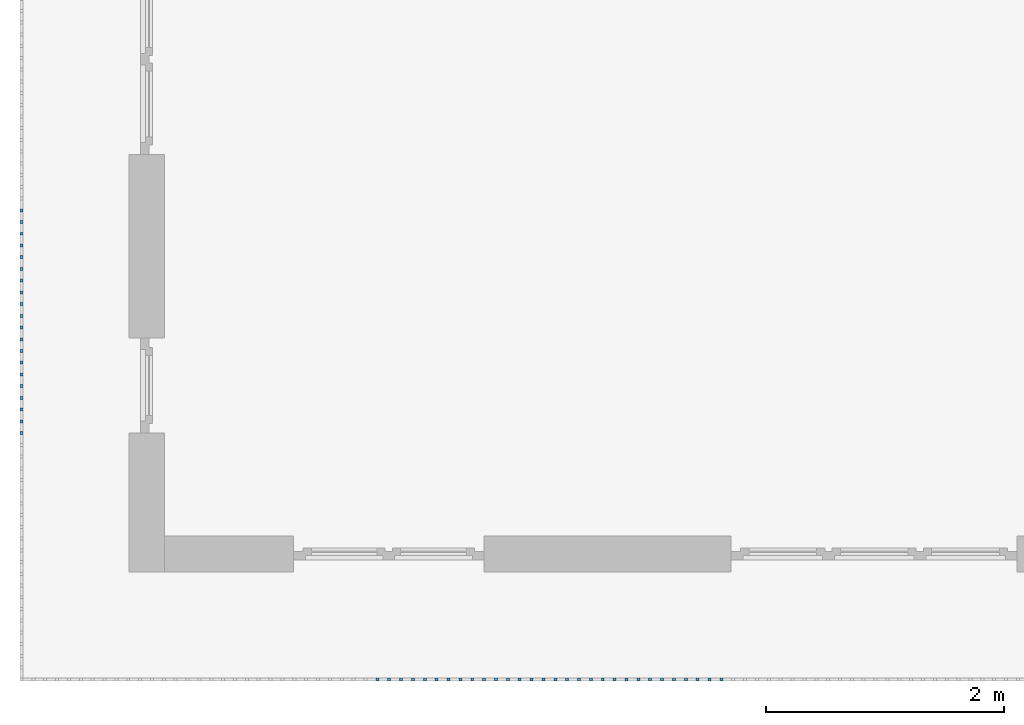
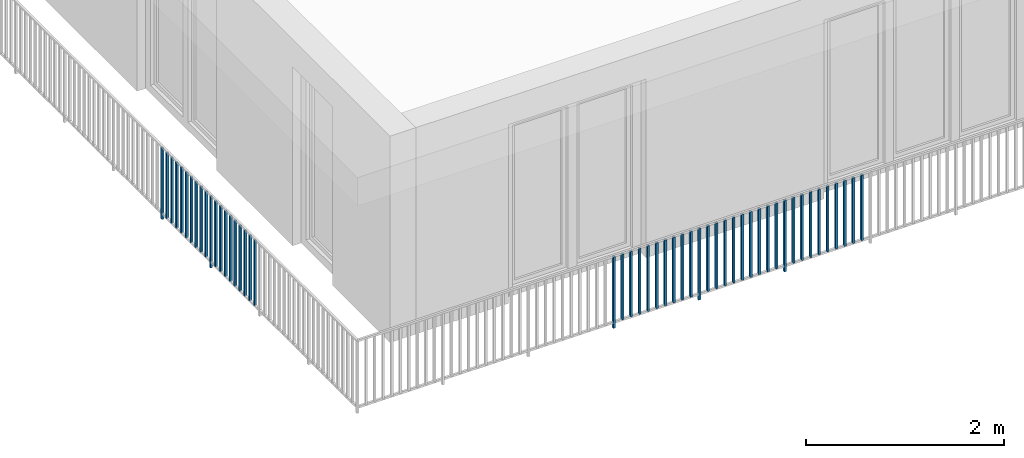
# One storey, part 26 of 48: 50 building element parts, 1 element without a shape of its own.
"""IFC4 building model written with IfcOpenShell, lengths in metres."""

from ifc_helpers import new_model, entity, si_unit, converted_unit, derived_unit, direction, frame, origin_with_axes, place, context, subcontext, project, spatial, polygons, material, type_object, element, aggregate, save


model = new_model("IFC4")

# Units and contexts
model_context = context("Model", 3, precision=1e-05, world=origin_with_axes(), true_north=direction((0.0, 1.0)))
body_context = subcontext(model_context, "Body", "Model", "MODEL_VIEW")
ifc_project = project(units=[si_unit("LENGTHUNIT", "METRE"), si_unit("AREAUNIT", "SQUARE_METRE"), si_unit("VOLUMEUNIT", "CUBIC_METRE"), converted_unit("PLANEANGLEUNIT", "DEGREE", entity("IfcPlaneAngleMeasure", 0.0174532925199), si_unit("PLANEANGLEUNIT", "RADIAN"), dimensions=[0, 0, 0, 0, 0, 0, 0]), converted_unit("TIMEUNIT", "Year", entity("IfcTimeMeasure", 31556926.0), si_unit("TIMEUNIT", "SECOND"), dimensions=[0, 0, 1, 0, 0, 0, 0]), si_unit("MASSUNIT", "GRAM", prefix="KILO"), si_unit("THERMODYNAMICTEMPERATUREUNIT", "DEGREE_CELSIUS"), si_unit("LUMINOUSINTENSITYUNIT", "LUMEN"), si_unit("ENERGYUNIT", "JOULE", prefix="MEGA"), derived_unit("THERMALCONDUCTANCEUNIT", [(si_unit("POWERUNIT", "WATT"), 1), (si_unit("LENGTHUNIT", "METRE"), -1), (si_unit("THERMODYNAMICTEMPERATUREUNIT", "KELVIN"), -1)]), derived_unit("SPECIFICHEATCAPACITYUNIT", [(si_unit("ENERGYUNIT", "JOULE"), 1), (si_unit("MASSUNIT", "GRAM", prefix="KILO"), -1), (si_unit("THERMODYNAMICTEMPERATUREUNIT", "KELVIN"), -1)]), derived_unit("MASSDENSITYUNIT", [(si_unit("MASSUNIT", "GRAM", prefix="KILO"), 1), (si_unit("VOLUMEUNIT", "CUBIC_METRE"), -1)])], contexts=[model_context])

# Site, building, storey
site_placement = place(None, origin_with_axes())
site = spatial("IfcSite", under=ifc_project, at=site_placement, CompositionType="ELEMENT")
building_placement = place(site_placement, origin_with_axes())
building = spatial("IfcBuilding", under=site, at=building_placement, CompositionType="ELEMENT")
storey_placement = place(building_placement, frame((0.0, 0.0, 3.4), z_axis=(0.0, 0.0, 1.0), x_axis=(1.0, 0.0, 0.0)))
storey = spatial("IfcBuildingStorey", under=building, at=storey_placement, Name="1. Geschoss", CompositionType="ELEMENT", Elevation=3.4)

# Railing, building element parts
railing_type = type_object("IfcRailingType", PredefinedType="NOTDEFINED")
railing_placement = place(storey_placement, frame((10.2378006196, 9.82118776896, 0.0), z_axis=(0.0, 0.0, 1.0), x_axis=(1.0, 0.0, 0.0)))
railing = element("IfcRailing", 1, at=railing_placement, inside=storey, type_object=railing_type, PredefinedType="NOTDEFINED")
ifc_material = material()
building_element_part_1_placement = place(railing_placement, origin_with_axes())
building_element_part_1 = element("IfcBuildingElementPart", 2, at=building_element_part_1_placement, material=ifc_material, PredefinedType="NOTDEFINED", context=body_context, shape_type="Tessellation", body=[
    polygons([(-22.8925, -16.7291666667, 0.0), (-22.8675, -16.7291666667, 0.0), (-22.8675, -16.7291666667, 0.88), (-22.8925, -16.7291666667, 0.88), (-22.8925, -16.7041666667, 0.0), (-22.8675, -16.7041666667, 0.0), (-22.8675, -16.7041666667, 0.88), (-22.8925, -16.7041666667, 0.88)], [[[1, 2, 3, 4]], [[1, 5, 6, 2]], [[2, 6, 7, 3]], [[4, 3, 7, 8]], [[5, 1, 4, 8]], [[6, 5, 8, 7]]], closed=True),
])
building_element_part_2_placement = place(railing_placement, origin_with_axes())
building_element_part_2 = element("IfcBuildingElementPart", 3, at=building_element_part_2_placement, material=ifc_material, PredefinedType="NOTDEFINED", context=body_context, shape_type="Tessellation", body=[
    polygons([(-22.8925, -16.8275, 0.07), (-22.8675, -16.8275, 0.07), (-22.8675, -16.8275, 0.8775), (-22.8925, -16.8275, 0.8775), (-22.8925, -16.8025, 0.07), (-22.8675, -16.8025, 0.07), (-22.8675, -16.8025, 0.8775), (-22.8925, -16.8025, 0.8775)], [[[1, 2, 3, 4]], [[1, 5, 6, 2]], [[2, 6, 7, 3]], [[4, 3, 7, 8]], [[5, 1, 4, 8]], [[6, 5, 8, 7]]], closed=True),
])
building_element_part_3_placement = place(railing_placement, origin_with_axes())
building_element_part_3 = element("IfcBuildingElementPart", 4, at=building_element_part_3_placement, material=ifc_material, PredefinedType="NOTDEFINED", context=body_context, shape_type="Tessellation", body=[
    polygons([(-22.8925, -16.9258333333, 0.07), (-22.8675, -16.9258333333, 0.07), (-22.8675, -16.9258333333, 0.8775), (-22.8925, -16.9258333333, 0.8775), (-22.8925, -16.9008333333, 0.07), (-22.8675, -16.9008333333, 0.07), (-22.8675, -16.9008333333, 0.8775), (-22.8925, -16.9008333333, 0.8775)], [[[1, 2, 3, 4]], [[1, 5, 6, 2]], [[2, 6, 7, 3]], [[4, 3, 7, 8]], [[5, 1, 4, 8]], [[6, 5, 8, 7]]], closed=True),
])
building_element_part_4_placement = place(railing_placement, origin_with_axes())
building_element_part_4 = element("IfcBuildingElementPart", 5, at=building_element_part_4_placement, material=ifc_material, PredefinedType="NOTDEFINED", context=body_context, shape_type="Tessellation", body=[
    polygons([(-22.8925, -17.0241666667, 0.07), (-22.8675, -17.0241666667, 0.07), (-22.8675, -17.0241666667, 0.8775), (-22.8925, -17.0241666667, 0.8775), (-22.8925, -16.9991666667, 0.07), (-22.8675, -16.9991666667, 0.07), (-22.8675, -16.9991666667, 0.8775), (-22.8925, -16.9991666667, 0.8775)], [[[1, 2, 3, 4]], [[1, 5, 6, 2]], [[2, 6, 7, 3]], [[4, 3, 7, 8]], [[5, 1, 4, 8]], [[6, 5, 8, 7]]], closed=True),
])
building_element_part_5_placement = place(railing_placement, origin_with_axes())
building_element_part_5 = element("IfcBuildingElementPart", 6, at=building_element_part_5_placement, material=ifc_material, PredefinedType="NOTDEFINED", context=body_context, shape_type="Tessellation", body=[
    polygons([(-22.8925, -17.1225, 0.07), (-22.8675, -17.1225, 0.07), (-22.8675, -17.1225, 0.8775), (-22.8925, -17.1225, 0.8775), (-22.8925, -17.0975, 0.07), (-22.8675, -17.0975, 0.07), (-22.8675, -17.0975, 0.8775), (-22.8925, -17.0975, 0.8775)], [[[1, 2, 3, 4]], [[1, 5, 6, 2]], [[2, 6, 7, 3]], [[4, 3, 7, 8]], [[5, 1, 4, 8]], [[6, 5, 8, 7]]], closed=True),
])
building_element_part_6_placement = place(railing_placement, origin_with_axes())
building_element_part_6 = element("IfcBuildingElementPart", 7, at=building_element_part_6_placement, material=ifc_material, PredefinedType="NOTDEFINED", context=body_context, shape_type="Tessellation", body=[
    polygons([(-22.8925, -17.2208333333, 0.07), (-22.8675, -17.2208333333, 0.07), (-22.8675, -17.2208333333, 0.8775), (-22.8925, -17.2208333333, 0.8775), (-22.8925, -17.1958333333, 0.07), (-22.8675, -17.1958333333, 0.07), (-22.8675, -17.1958333333, 0.8775), (-22.8925, -17.1958333333, 0.8775)], [[[1, 2, 3, 4]], [[1, 5, 6, 2]], [[2, 6, 7, 3]], [[4, 3, 7, 8]], [[5, 1, 4, 8]], [[6, 5, 8, 7]]], closed=True),
])
building_element_part_7_placement = place(railing_placement, origin_with_axes())
building_element_part_7 = element("IfcBuildingElementPart", 8, at=building_element_part_7_placement, material=ifc_material, PredefinedType="NOTDEFINED", context=body_context, shape_type="Tessellation", body=[
    polygons([(-22.8925, -17.3191666667, 0.07), (-22.8675, -17.3191666667, 0.07), (-22.8675, -17.3191666667, 0.8775), (-22.8925, -17.3191666667, 0.8775), (-22.8925, -17.2941666667, 0.07), (-22.8675, -17.2941666667, 0.07), (-22.8675, -17.2941666667, 0.8775), (-22.8925, -17.2941666667, 0.8775)], [[[1, 2, 3, 4]], [[1, 5, 6, 2]], [[2, 6, 7, 3]], [[4, 3, 7, 8]], [[5, 1, 4, 8]], [[6, 5, 8, 7]]], closed=True),
])
building_element_part_8_placement = place(railing_placement, origin_with_axes())
building_element_part_8 = element("IfcBuildingElementPart", 9, at=building_element_part_8_placement, material=ifc_material, PredefinedType="NOTDEFINED", context=body_context, shape_type="Tessellation", body=[
    polygons([(-22.8925, -17.4175, 0.07), (-22.8675, -17.4175, 0.07), (-22.8675, -17.4175, 0.8775), (-22.8925, -17.4175, 0.8775), (-22.8925, -17.3925, 0.07), (-22.8675, -17.3925, 0.07), (-22.8675, -17.3925, 0.8775), (-22.8925, -17.3925, 0.8775)], [[[1, 2, 3, 4]], [[1, 5, 6, 2]], [[2, 6, 7, 3]], [[4, 3, 7, 8]], [[5, 1, 4, 8]], [[6, 5, 8, 7]]], closed=True),
])
building_element_part_9_placement = place(railing_placement, origin_with_axes())
building_element_part_9 = element("IfcBuildingElementPart", 10, at=building_element_part_9_placement, material=ifc_material, PredefinedType="NOTDEFINED", context=body_context, shape_type="Tessellation", body=[
    polygons([(-22.8925, -17.5158333333, 0.07), (-22.8675, -17.5158333333, 0.07), (-22.8675, -17.5158333333, 0.8775), (-22.8925, -17.5158333333, 0.8775), (-22.8925, -17.4908333333, 0.07), (-22.8675, -17.4908333333, 0.07), (-22.8675, -17.4908333333, 0.8775), (-22.8925, -17.4908333333, 0.8775)], [[[1, 2, 3, 4]], [[1, 5, 6, 2]], [[2, 6, 7, 3]], [[4, 3, 7, 8]], [[5, 1, 4, 8]], [[6, 5, 8, 7]]], closed=True),
])
building_element_part_10_placement = place(railing_placement, origin_with_axes())
building_element_part_10 = element("IfcBuildingElementPart", 11, at=building_element_part_10_placement, material=ifc_material, PredefinedType="NOTDEFINED", context=body_context, shape_type="Tessellation", body=[
    polygons([(-22.8925, -17.6141666667, 0.07), (-22.8675, -17.6141666667, 0.07), (-22.8675, -17.6141666667, 0.8775), (-22.8925, -17.6141666667, 0.8775), (-22.8925, -17.5891666667, 0.07), (-22.8675, -17.5891666667, 0.07), (-22.8675, -17.5891666667, 0.8775), (-22.8925, -17.5891666667, 0.8775)], [[[1, 2, 3, 4]], [[1, 5, 6, 2]], [[2, 6, 7, 3]], [[4, 3, 7, 8]], [[5, 1, 4, 8]], [[6, 5, 8, 7]]], closed=True),
])
building_element_part_11_placement = place(railing_placement, origin_with_axes())
building_element_part_11 = element("IfcBuildingElementPart", 12, at=building_element_part_11_placement, material=ifc_material, PredefinedType="NOTDEFINED", context=body_context, shape_type="Tessellation", body=[
    polygons([(-22.8925, -17.7125, 0.0), (-22.8675, -17.7125, 0.0), (-22.8675, -17.7125, 0.88), (-22.8925, -17.7125, 0.88), (-22.8925, -17.6875, 0.0), (-22.8675, -17.6875, 0.0), (-22.8675, -17.6875, 0.88), (-22.8925, -17.6875, 0.88)], [[[1, 2, 3, 4]], [[1, 5, 6, 2]], [[2, 6, 7, 3]], [[4, 3, 7, 8]], [[5, 1, 4, 8]], [[6, 5, 8, 7]]], closed=True),
])
building_element_part_12_placement = place(railing_placement, origin_with_axes())
building_element_part_12 = element("IfcBuildingElementPart", 13, at=building_element_part_12_placement, material=ifc_material, PredefinedType="NOTDEFINED", context=body_context, shape_type="Tessellation", body=[
    polygons([(-22.8925, -17.8108333333, 0.07), (-22.8675, -17.8108333333, 0.07), (-22.8675, -17.8108333333, 0.8775), (-22.8925, -17.8108333333, 0.8775), (-22.8925, -17.7858333333, 0.07), (-22.8675, -17.7858333333, 0.07), (-22.8675, -17.7858333333, 0.8775), (-22.8925, -17.7858333333, 0.8775)], [[[1, 2, 3, 4]], [[1, 5, 6, 2]], [[2, 6, 7, 3]], [[4, 3, 7, 8]], [[5, 1, 4, 8]], [[6, 5, 8, 7]]], closed=True),
])
building_element_part_13_placement = place(railing_placement, origin_with_axes())
building_element_part_13 = element("IfcBuildingElementPart", 14, at=building_element_part_13_placement, material=ifc_material, PredefinedType="NOTDEFINED", context=body_context, shape_type="Tessellation", body=[
    polygons([(-22.8925, -17.9091666667, 0.07), (-22.8675, -17.9091666667, 0.07), (-22.8675, -17.9091666667, 0.8775), (-22.8925, -17.9091666667, 0.8775), (-22.8925, -17.8841666667, 0.07), (-22.8675, -17.8841666667, 0.07), (-22.8675, -17.8841666667, 0.8775), (-22.8925, -17.8841666667, 0.8775)], [[[1, 2, 3, 4]], [[1, 5, 6, 2]], [[2, 6, 7, 3]], [[4, 3, 7, 8]], [[5, 1, 4, 8]], [[6, 5, 8, 7]]], closed=True),
])
building_element_part_14_placement = place(railing_placement, origin_with_axes())
building_element_part_14 = element("IfcBuildingElementPart", 15, at=building_element_part_14_placement, material=ifc_material, PredefinedType="NOTDEFINED", context=body_context, shape_type="Tessellation", body=[
    polygons([(-22.8925, -18.0075, 0.07), (-22.8675, -18.0075, 0.07), (-22.8675, -18.0075, 0.8775), (-22.8925, -18.0075, 0.8775), (-22.8925, -17.9825, 0.07), (-22.8675, -17.9825, 0.07), (-22.8675, -17.9825, 0.8775), (-22.8925, -17.9825, 0.8775)], [[[1, 2, 3, 4]], [[1, 5, 6, 2]], [[2, 6, 7, 3]], [[4, 3, 7, 8]], [[5, 1, 4, 8]], [[6, 5, 8, 7]]], closed=True),
])
building_element_part_15_placement = place(railing_placement, origin_with_axes())
building_element_part_15 = element("IfcBuildingElementPart", 16, at=building_element_part_15_placement, material=ifc_material, PredefinedType="NOTDEFINED", context=body_context, shape_type="Tessellation", body=[
    polygons([(-22.8925, -18.1058333333, 0.07), (-22.8675, -18.1058333333, 0.07), (-22.8675, -18.1058333333, 0.8775), (-22.8925, -18.1058333333, 0.8775), (-22.8925, -18.0808333333, 0.07), (-22.8675, -18.0808333333, 0.07), (-22.8675, -18.0808333333, 0.8775), (-22.8925, -18.0808333333, 0.8775)], [[[1, 2, 3, 4]], [[1, 5, 6, 2]], [[2, 6, 7, 3]], [[4, 3, 7, 8]], [[5, 1, 4, 8]], [[6, 5, 8, 7]]], closed=True),
])
building_element_part_16_placement = place(railing_placement, origin_with_axes())
building_element_part_16 = element("IfcBuildingElementPart", 17, at=building_element_part_16_placement, material=ifc_material, PredefinedType="NOTDEFINED", context=body_context, shape_type="Tessellation", body=[
    polygons([(-22.8925, -18.2041666667, 0.07), (-22.8675, -18.2041666667, 0.07), (-22.8675, -18.2041666667, 0.8775), (-22.8925, -18.2041666667, 0.8775), (-22.8925, -18.1791666667, 0.07), (-22.8675, -18.1791666667, 0.07), (-22.8675, -18.1791666667, 0.8775), (-22.8925, -18.1791666667, 0.8775)], [[[1, 2, 3, 4]], [[1, 5, 6, 2]], [[2, 6, 7, 3]], [[4, 3, 7, 8]], [[5, 1, 4, 8]], [[6, 5, 8, 7]]], closed=True),
])
building_element_part_17_placement = place(railing_placement, origin_with_axes())
building_element_part_17 = element("IfcBuildingElementPart", 18, at=building_element_part_17_placement, material=ifc_material, PredefinedType="NOTDEFINED", context=body_context, shape_type="Tessellation", body=[
    polygons([(-22.8925, -18.3025, 0.07), (-22.8675, -18.3025, 0.07), (-22.8675, -18.3025, 0.8775), (-22.8925, -18.3025, 0.8775), (-22.8925, -18.2775, 0.07), (-22.8675, -18.2775, 0.07), (-22.8675, -18.2775, 0.8775), (-22.8925, -18.2775, 0.8775)], [[[1, 2, 3, 4]], [[1, 5, 6, 2]], [[2, 6, 7, 3]], [[4, 3, 7, 8]], [[5, 1, 4, 8]], [[6, 5, 8, 7]]], closed=True),
])
building_element_part_18_placement = place(railing_placement, origin_with_axes())
building_element_part_18 = element("IfcBuildingElementPart", 19, at=building_element_part_18_placement, material=ifc_material, PredefinedType="NOTDEFINED", context=body_context, shape_type="Tessellation", body=[
    polygons([(-22.8925, -18.4008333333, 0.07), (-22.8675, -18.4008333333, 0.07), (-22.8675, -18.4008333333, 0.8775), (-22.8925, -18.4008333333, 0.8775), (-22.8925, -18.3758333333, 0.07), (-22.8675, -18.3758333333, 0.07), (-22.8675, -18.3758333333, 0.8775), (-22.8925, -18.3758333333, 0.8775)], [[[1, 2, 3, 4]], [[1, 5, 6, 2]], [[2, 6, 7, 3]], [[4, 3, 7, 8]], [[5, 1, 4, 8]], [[6, 5, 8, 7]]], closed=True),
])
building_element_part_19_placement = place(railing_placement, origin_with_axes())
building_element_part_19 = element("IfcBuildingElementPart", 20, at=building_element_part_19_placement, material=ifc_material, PredefinedType="NOTDEFINED", context=body_context, shape_type="Tessellation", body=[
    polygons([(-22.8925, -18.4991666667, 0.07), (-22.8675, -18.4991666667, 0.07), (-22.8675, -18.4991666667, 0.8775), (-22.8925, -18.4991666667, 0.8775), (-22.8925, -18.4741666667, 0.07), (-22.8675, -18.4741666667, 0.07), (-22.8675, -18.4741666667, 0.8775), (-22.8925, -18.4741666667, 0.8775)], [[[1, 2, 3, 4]], [[1, 5, 6, 2]], [[2, 6, 7, 3]], [[4, 3, 7, 8]], [[5, 1, 4, 8]], [[6, 5, 8, 7]]], closed=True),
])
building_element_part_20_placement = place(railing_placement, origin_with_axes())
building_element_part_20 = element("IfcBuildingElementPart", 21, at=building_element_part_20_placement, material=ifc_material, PredefinedType="NOTDEFINED", context=body_context, shape_type="Tessellation", body=[
    polygons([(-22.8925, -18.5975, 0.07), (-22.8675, -18.5975, 0.07), (-22.8675, -18.5975, 0.8775), (-22.8925, -18.5975, 0.8775), (-22.8925, -18.5725, 0.07), (-22.8675, -18.5725, 0.07), (-22.8675, -18.5725, 0.8775), (-22.8925, -18.5725, 0.8775)], [[[1, 2, 3, 4]], [[1, 5, 6, 2]], [[2, 6, 7, 3]], [[4, 3, 7, 8]], [[5, 1, 4, 8]], [[6, 5, 8, 7]]], closed=True),
])
building_element_part_21_placement = place(railing_placement, origin_with_axes())
building_element_part_21 = element("IfcBuildingElementPart", 22, at=building_element_part_21_placement, material=ifc_material, PredefinedType="NOTDEFINED", context=body_context, shape_type="Tessellation", body=[
    polygons([(-19.8831521739, -20.6625, 0.0), (-19.8831521739, -20.6375, 0.0), (-19.8831521739, -20.6375, 0.88), (-19.8831521739, -20.6625, 0.88), (-19.9081521739, -20.6625, 0.0), (-19.9081521739, -20.6375, 0.0), (-19.9081521739, -20.6375, 0.88), (-19.9081521739, -20.6625, 0.88)], [[[1, 2, 3, 4]], [[1, 5, 6, 2]], [[2, 6, 7, 3]], [[4, 3, 7, 8]], [[5, 1, 4, 8]], [[6, 5, 8, 7]]], closed=True),
])
building_element_part_22_placement = place(railing_placement, origin_with_axes())
building_element_part_22 = element("IfcBuildingElementPart", 23, at=building_element_part_22_placement, material=ifc_material, PredefinedType="NOTDEFINED", context=body_context, shape_type="Tessellation", body=[
    polygons([(-19.783673913, -20.6625, 0.07), (-19.783673913, -20.6375, 0.07), (-19.783673913, -20.6375, 0.8775), (-19.783673913, -20.6625, 0.8775), (-19.808673913, -20.6625, 0.07), (-19.808673913, -20.6375, 0.07), (-19.808673913, -20.6375, 0.8775), (-19.808673913, -20.6625, 0.8775)], [[[1, 2, 3, 4]], [[1, 5, 6, 2]], [[2, 6, 7, 3]], [[4, 3, 7, 8]], [[5, 1, 4, 8]], [[6, 5, 8, 7]]], closed=True),
])
building_element_part_23_placement = place(railing_placement, origin_with_axes())
building_element_part_23 = element("IfcBuildingElementPart", 24, at=building_element_part_23_placement, material=ifc_material, PredefinedType="NOTDEFINED", context=body_context, shape_type="Tessellation", body=[
    polygons([(-19.6841956522, -20.6625, 0.07), (-19.6841956522, -20.6375, 0.07), (-19.6841956522, -20.6375, 0.8775), (-19.6841956522, -20.6625, 0.8775), (-19.7091956522, -20.6625, 0.07), (-19.7091956522, -20.6375, 0.07), (-19.7091956522, -20.6375, 0.8775), (-19.7091956522, -20.6625, 0.8775)], [[[1, 2, 3, 4]], [[1, 5, 6, 2]], [[2, 6, 7, 3]], [[4, 3, 7, 8]], [[5, 1, 4, 8]], [[6, 5, 8, 7]]], closed=True),
])
building_element_part_24_placement = place(railing_placement, origin_with_axes())
building_element_part_24 = element("IfcBuildingElementPart", 25, at=building_element_part_24_placement, material=ifc_material, PredefinedType="NOTDEFINED", context=body_context, shape_type="Tessellation", body=[
    polygons([(-19.5847173913, -20.6625, 0.07), (-19.5847173913, -20.6375, 0.07), (-19.5847173913, -20.6375, 0.8775), (-19.5847173913, -20.6625, 0.8775), (-19.6097173913, -20.6625, 0.07), (-19.6097173913, -20.6375, 0.07), (-19.6097173913, -20.6375, 0.8775), (-19.6097173913, -20.6625, 0.8775)], [[[1, 2, 3, 4]], [[1, 5, 6, 2]], [[2, 6, 7, 3]], [[4, 3, 7, 8]], [[5, 1, 4, 8]], [[6, 5, 8, 7]]], closed=True),
])
building_element_part_25_placement = place(railing_placement, origin_with_axes())
building_element_part_25 = element("IfcBuildingElementPart", 26, at=building_element_part_25_placement, material=ifc_material, PredefinedType="NOTDEFINED", context=body_context, shape_type="Tessellation", body=[
    polygons([(-19.4852391304, -20.6625, 0.07), (-19.4852391304, -20.6375, 0.07), (-19.4852391304, -20.6375, 0.8775), (-19.4852391304, -20.6625, 0.8775), (-19.5102391304, -20.6625, 0.07), (-19.5102391304, -20.6375, 0.07), (-19.5102391304, -20.6375, 0.8775), (-19.5102391304, -20.6625, 0.8775)], [[[1, 2, 3, 4]], [[1, 5, 6, 2]], [[2, 6, 7, 3]], [[4, 3, 7, 8]], [[5, 1, 4, 8]], [[6, 5, 8, 7]]], closed=True),
])
building_element_part_26_placement = place(railing_placement, origin_with_axes())
building_element_part_26 = element("IfcBuildingElementPart", 27, at=building_element_part_26_placement, material=ifc_material, PredefinedType="NOTDEFINED", context=body_context, shape_type="Tessellation", body=[
    polygons([(-19.3857608696, -20.6625, 0.07), (-19.3857608696, -20.6375, 0.07), (-19.3857608696, -20.6375, 0.8775), (-19.3857608696, -20.6625, 0.8775), (-19.4107608696, -20.6625, 0.07), (-19.4107608696, -20.6375, 0.07), (-19.4107608696, -20.6375, 0.8775), (-19.4107608696, -20.6625, 0.8775)], [[[1, 2, 3, 4]], [[1, 5, 6, 2]], [[2, 6, 7, 3]], [[4, 3, 7, 8]], [[5, 1, 4, 8]], [[6, 5, 8, 7]]], closed=True),
])
building_element_part_27_placement = place(railing_placement, origin_with_axes())
building_element_part_27 = element("IfcBuildingElementPart", 28, at=building_element_part_27_placement, material=ifc_material, PredefinedType="NOTDEFINED", context=body_context, shape_type="Tessellation", body=[
    polygons([(-19.2862826087, -20.6625, 0.07), (-19.2862826087, -20.6375, 0.07), (-19.2862826087, -20.6375, 0.8775), (-19.2862826087, -20.6625, 0.8775), (-19.3112826087, -20.6625, 0.07), (-19.3112826087, -20.6375, 0.07), (-19.3112826087, -20.6375, 0.8775), (-19.3112826087, -20.6625, 0.8775)], [[[1, 2, 3, 4]], [[1, 5, 6, 2]], [[2, 6, 7, 3]], [[4, 3, 7, 8]], [[5, 1, 4, 8]], [[6, 5, 8, 7]]], closed=True),
])
building_element_part_28_placement = place(railing_placement, origin_with_axes())
building_element_part_28 = element("IfcBuildingElementPart", 29, at=building_element_part_28_placement, material=ifc_material, PredefinedType="NOTDEFINED", context=body_context, shape_type="Tessellation", body=[
    polygons([(-19.1868043478, -20.6625, 0.07), (-19.1868043478, -20.6375, 0.07), (-19.1868043478, -20.6375, 0.8775), (-19.1868043478, -20.6625, 0.8775), (-19.2118043478, -20.6625, 0.07), (-19.2118043478, -20.6375, 0.07), (-19.2118043478, -20.6375, 0.8775), (-19.2118043478, -20.6625, 0.8775)], [[[1, 2, 3, 4]], [[1, 5, 6, 2]], [[2, 6, 7, 3]], [[4, 3, 7, 8]], [[5, 1, 4, 8]], [[6, 5, 8, 7]]], closed=True),
])
building_element_part_29_placement = place(railing_placement, origin_with_axes())
building_element_part_29 = element("IfcBuildingElementPart", 30, at=building_element_part_29_placement, material=ifc_material, PredefinedType="NOTDEFINED", context=body_context, shape_type="Tessellation", body=[
    polygons([(-19.087326087, -20.6625, 0.07), (-19.087326087, -20.6375, 0.07), (-19.087326087, -20.6375, 0.8775), (-19.087326087, -20.6625, 0.8775), (-19.112326087, -20.6625, 0.07), (-19.112326087, -20.6375, 0.07), (-19.112326087, -20.6375, 0.8775), (-19.112326087, -20.6625, 0.8775)], [[[1, 2, 3, 4]], [[1, 5, 6, 2]], [[2, 6, 7, 3]], [[4, 3, 7, 8]], [[5, 1, 4, 8]], [[6, 5, 8, 7]]], closed=True),
])
building_element_part_30_placement = place(railing_placement, origin_with_axes())
building_element_part_30 = element("IfcBuildingElementPart", 31, at=building_element_part_30_placement, material=ifc_material, PredefinedType="NOTDEFINED", context=body_context, shape_type="Tessellation", body=[
    polygons([(-18.9878478261, -20.6625, 0.07), (-18.9878478261, -20.6375, 0.07), (-18.9878478261, -20.6375, 0.8775), (-18.9878478261, -20.6625, 0.8775), (-19.0128478261, -20.6625, 0.07), (-19.0128478261, -20.6375, 0.07), (-19.0128478261, -20.6375, 0.8775), (-19.0128478261, -20.6625, 0.8775)], [[[1, 2, 3, 4]], [[1, 5, 6, 2]], [[2, 6, 7, 3]], [[4, 3, 7, 8]], [[5, 1, 4, 8]], [[6, 5, 8, 7]]], closed=True),
])
building_element_part_31_placement = place(railing_placement, origin_with_axes())
building_element_part_31 = element("IfcBuildingElementPart", 32, at=building_element_part_31_placement, material=ifc_material, PredefinedType="NOTDEFINED", context=body_context, shape_type="Tessellation", body=[
    polygons([(-18.8883695652, -20.6625, 0.0), (-18.8883695652, -20.6375, 0.0), (-18.8883695652, -20.6375, 0.88), (-18.8883695652, -20.6625, 0.88), (-18.9133695652, -20.6625, 0.0), (-18.9133695652, -20.6375, 0.0), (-18.9133695652, -20.6375, 0.88), (-18.9133695652, -20.6625, 0.88)], [[[1, 2, 3, 4]], [[1, 5, 6, 2]], [[2, 6, 7, 3]], [[4, 3, 7, 8]], [[5, 1, 4, 8]], [[6, 5, 8, 7]]], closed=True),
])
building_element_part_32_placement = place(railing_placement, origin_with_axes())
building_element_part_32 = element("IfcBuildingElementPart", 33, at=building_element_part_32_placement, material=ifc_material, PredefinedType="NOTDEFINED", context=body_context, shape_type="Tessellation", body=[
    polygons([(-18.7888913043, -20.6625, 0.07), (-18.7888913043, -20.6375, 0.07), (-18.7888913043, -20.6375, 0.8775), (-18.7888913043, -20.6625, 0.8775), (-18.8138913043, -20.6625, 0.07), (-18.8138913043, -20.6375, 0.07), (-18.8138913043, -20.6375, 0.8775), (-18.8138913043, -20.6625, 0.8775)], [[[1, 2, 3, 4]], [[1, 5, 6, 2]], [[2, 6, 7, 3]], [[4, 3, 7, 8]], [[5, 1, 4, 8]], [[6, 5, 8, 7]]], closed=True),
])
building_element_part_33_placement = place(railing_placement, origin_with_axes())
building_element_part_33 = element("IfcBuildingElementPart", 34, at=building_element_part_33_placement, material=ifc_material, PredefinedType="NOTDEFINED", context=body_context, shape_type="Tessellation", body=[
    polygons([(-18.6894130435, -20.6625, 0.07), (-18.6894130435, -20.6375, 0.07), (-18.6894130435, -20.6375, 0.8775), (-18.6894130435, -20.6625, 0.8775), (-18.7144130435, -20.6625, 0.07), (-18.7144130435, -20.6375, 0.07), (-18.7144130435, -20.6375, 0.8775), (-18.7144130435, -20.6625, 0.8775)], [[[1, 2, 3, 4]], [[1, 5, 6, 2]], [[2, 6, 7, 3]], [[4, 3, 7, 8]], [[5, 1, 4, 8]], [[6, 5, 8, 7]]], closed=True),
])
building_element_part_34_placement = place(railing_placement, origin_with_axes())
building_element_part_34 = element("IfcBuildingElementPart", 35, at=building_element_part_34_placement, material=ifc_material, PredefinedType="NOTDEFINED", context=body_context, shape_type="Tessellation", body=[
    polygons([(-18.5899347826, -20.6625, 0.07), (-18.5899347826, -20.6375, 0.07), (-18.5899347826, -20.6375, 0.8775), (-18.5899347826, -20.6625, 0.8775), (-18.6149347826, -20.6625, 0.07), (-18.6149347826, -20.6375, 0.07), (-18.6149347826, -20.6375, 0.8775), (-18.6149347826, -20.6625, 0.8775)], [[[1, 2, 3, 4]], [[1, 5, 6, 2]], [[2, 6, 7, 3]], [[4, 3, 7, 8]], [[5, 1, 4, 8]], [[6, 5, 8, 7]]], closed=True),
])
building_element_part_35_placement = place(railing_placement, origin_with_axes())
building_element_part_35 = element("IfcBuildingElementPart", 36, at=building_element_part_35_placement, material=ifc_material, PredefinedType="NOTDEFINED", context=body_context, shape_type="Tessellation", body=[
    polygons([(-18.4904565217, -20.6625, 0.07), (-18.4904565217, -20.6375, 0.07), (-18.4904565217, -20.6375, 0.8775), (-18.4904565217, -20.6625, 0.8775), (-18.5154565217, -20.6625, 0.07), (-18.5154565217, -20.6375, 0.07), (-18.5154565217, -20.6375, 0.8775), (-18.5154565217, -20.6625, 0.8775)], [[[1, 2, 3, 4]], [[1, 5, 6, 2]], [[2, 6, 7, 3]], [[4, 3, 7, 8]], [[5, 1, 4, 8]], [[6, 5, 8, 7]]], closed=True),
])
building_element_part_36_placement = place(railing_placement, origin_with_axes())
building_element_part_36 = element("IfcBuildingElementPart", 37, at=building_element_part_36_placement, material=ifc_material, PredefinedType="NOTDEFINED", context=body_context, shape_type="Tessellation", body=[
    polygons([(-18.3909782609, -20.6625, 0.07), (-18.3909782609, -20.6375, 0.07), (-18.3909782609, -20.6375, 0.8775), (-18.3909782609, -20.6625, 0.8775), (-18.4159782609, -20.6625, 0.07), (-18.4159782609, -20.6375, 0.07), (-18.4159782609, -20.6375, 0.8775), (-18.4159782609, -20.6625, 0.8775)], [[[1, 2, 3, 4]], [[1, 5, 6, 2]], [[2, 6, 7, 3]], [[4, 3, 7, 8]], [[5, 1, 4, 8]], [[6, 5, 8, 7]]], closed=True),
])
building_element_part_37_placement = place(railing_placement, origin_with_axes())
building_element_part_37 = element("IfcBuildingElementPart", 38, at=building_element_part_37_placement, material=ifc_material, PredefinedType="NOTDEFINED", context=body_context, shape_type="Tessellation", body=[
    polygons([(-18.2915, -20.6625, 0.07), (-18.2915, -20.6375, 0.07), (-18.2915, -20.6375, 0.8775), (-18.2915, -20.6625, 0.8775), (-18.3165, -20.6625, 0.07), (-18.3165, -20.6375, 0.07), (-18.3165, -20.6375, 0.8775), (-18.3165, -20.6625, 0.8775)], [[[1, 2, 3, 4]], [[1, 5, 6, 2]], [[2, 6, 7, 3]], [[4, 3, 7, 8]], [[5, 1, 4, 8]], [[6, 5, 8, 7]]], closed=True),
])
building_element_part_38_placement = place(railing_placement, origin_with_axes())
building_element_part_38 = element("IfcBuildingElementPart", 39, at=building_element_part_38_placement, material=ifc_material, PredefinedType="NOTDEFINED", context=body_context, shape_type="Tessellation", body=[
    polygons([(-18.1920217391, -20.6625, 0.07), (-18.1920217391, -20.6375, 0.07), (-18.1920217391, -20.6375, 0.8775), (-18.1920217391, -20.6625, 0.8775), (-18.2170217391, -20.6625, 0.07), (-18.2170217391, -20.6375, 0.07), (-18.2170217391, -20.6375, 0.8775), (-18.2170217391, -20.6625, 0.8775)], [[[1, 2, 3, 4]], [[1, 5, 6, 2]], [[2, 6, 7, 3]], [[4, 3, 7, 8]], [[5, 1, 4, 8]], [[6, 5, 8, 7]]], closed=True),
])
building_element_part_39_placement = place(railing_placement, origin_with_axes())
building_element_part_39 = element("IfcBuildingElementPart", 40, at=building_element_part_39_placement, material=ifc_material, PredefinedType="NOTDEFINED", context=body_context, shape_type="Tessellation", body=[
    polygons([(-18.0925434783, -20.6625, 0.07), (-18.0925434783, -20.6375, 0.07), (-18.0925434783, -20.6375, 0.8775), (-18.0925434783, -20.6625, 0.8775), (-18.1175434783, -20.6625, 0.07), (-18.1175434783, -20.6375, 0.07), (-18.1175434783, -20.6375, 0.8775), (-18.1175434783, -20.6625, 0.8775)], [[[1, 2, 3, 4]], [[1, 5, 6, 2]], [[2, 6, 7, 3]], [[4, 3, 7, 8]], [[5, 1, 4, 8]], [[6, 5, 8, 7]]], closed=True),
])
building_element_part_40_placement = place(railing_placement, origin_with_axes())
building_element_part_40 = element("IfcBuildingElementPart", 41, at=building_element_part_40_placement, material=ifc_material, PredefinedType="NOTDEFINED", context=body_context, shape_type="Tessellation", body=[
    polygons([(-17.9930652174, -20.6625, 0.07), (-17.9930652174, -20.6375, 0.07), (-17.9930652174, -20.6375, 0.8775), (-17.9930652174, -20.6625, 0.8775), (-18.0180652174, -20.6625, 0.07), (-18.0180652174, -20.6375, 0.07), (-18.0180652174, -20.6375, 0.8775), (-18.0180652174, -20.6625, 0.8775)], [[[1, 2, 3, 4]], [[1, 5, 6, 2]], [[2, 6, 7, 3]], [[4, 3, 7, 8]], [[5, 1, 4, 8]], [[6, 5, 8, 7]]], closed=True),
])
building_element_part_41_placement = place(railing_placement, origin_with_axes())
building_element_part_41 = element("IfcBuildingElementPart", 42, at=building_element_part_41_placement, material=ifc_material, PredefinedType="NOTDEFINED", context=body_context, shape_type="Tessellation", body=[
    polygons([(-17.8935869565, -20.6625, 0.0), (-17.8935869565, -20.6375, 0.0), (-17.8935869565, -20.6375, 0.88), (-17.8935869565, -20.6625, 0.88), (-17.9185869565, -20.6625, 0.0), (-17.9185869565, -20.6375, 0.0), (-17.9185869565, -20.6375, 0.88), (-17.9185869565, -20.6625, 0.88)], [[[1, 2, 3, 4]], [[1, 5, 6, 2]], [[2, 6, 7, 3]], [[4, 3, 7, 8]], [[5, 1, 4, 8]], [[6, 5, 8, 7]]], closed=True),
])
building_element_part_42_placement = place(railing_placement, origin_with_axes())
building_element_part_42 = element("IfcBuildingElementPart", 43, at=building_element_part_42_placement, material=ifc_material, PredefinedType="NOTDEFINED", context=body_context, shape_type="Tessellation", body=[
    polygons([(-17.7941086957, -20.6625, 0.07), (-17.7941086957, -20.6375, 0.07), (-17.7941086957, -20.6375, 0.8775), (-17.7941086957, -20.6625, 0.8775), (-17.8191086957, -20.6625, 0.07), (-17.8191086957, -20.6375, 0.07), (-17.8191086957, -20.6375, 0.8775), (-17.8191086957, -20.6625, 0.8775)], [[[1, 2, 3, 4]], [[1, 5, 6, 2]], [[2, 6, 7, 3]], [[4, 3, 7, 8]], [[5, 1, 4, 8]], [[6, 5, 8, 7]]], closed=True),
])
building_element_part_43_placement = place(railing_placement, origin_with_axes())
building_element_part_43 = element("IfcBuildingElementPart", 44, at=building_element_part_43_placement, material=ifc_material, PredefinedType="NOTDEFINED", context=body_context, shape_type="Tessellation", body=[
    polygons([(-17.6946304348, -20.6625, 0.07), (-17.6946304348, -20.6375, 0.07), (-17.6946304348, -20.6375, 0.8775), (-17.6946304348, -20.6625, 0.8775), (-17.7196304348, -20.6625, 0.07), (-17.7196304348, -20.6375, 0.07), (-17.7196304348, -20.6375, 0.8775), (-17.7196304348, -20.6625, 0.8775)], [[[1, 2, 3, 4]], [[1, 5, 6, 2]], [[2, 6, 7, 3]], [[4, 3, 7, 8]], [[5, 1, 4, 8]], [[6, 5, 8, 7]]], closed=True),
])
building_element_part_44_placement = place(railing_placement, origin_with_axes())
building_element_part_44 = element("IfcBuildingElementPart", 45, at=building_element_part_44_placement, material=ifc_material, PredefinedType="NOTDEFINED", context=body_context, shape_type="Tessellation", body=[
    polygons([(-17.5951521739, -20.6625, 0.07), (-17.5951521739, -20.6375, 0.07), (-17.5951521739, -20.6375, 0.8775), (-17.5951521739, -20.6625, 0.8775), (-17.6201521739, -20.6625, 0.07), (-17.6201521739, -20.6375, 0.07), (-17.6201521739, -20.6375, 0.8775), (-17.6201521739, -20.6625, 0.8775)], [[[1, 2, 3, 4]], [[1, 5, 6, 2]], [[2, 6, 7, 3]], [[4, 3, 7, 8]], [[5, 1, 4, 8]], [[6, 5, 8, 7]]], closed=True),
])
building_element_part_45_placement = place(railing_placement, origin_with_axes())
building_element_part_45 = element("IfcBuildingElementPart", 46, at=building_element_part_45_placement, material=ifc_material, PredefinedType="NOTDEFINED", context=body_context, shape_type="Tessellation", body=[
    polygons([(-17.495673913, -20.6625, 0.07), (-17.495673913, -20.6375, 0.07), (-17.495673913, -20.6375, 0.8775), (-17.495673913, -20.6625, 0.8775), (-17.520673913, -20.6625, 0.07), (-17.520673913, -20.6375, 0.07), (-17.520673913, -20.6375, 0.8775), (-17.520673913, -20.6625, 0.8775)], [[[1, 2, 3, 4]], [[1, 5, 6, 2]], [[2, 6, 7, 3]], [[4, 3, 7, 8]], [[5, 1, 4, 8]], [[6, 5, 8, 7]]], closed=True),
])
building_element_part_46_placement = place(railing_placement, origin_with_axes())
building_element_part_46 = element("IfcBuildingElementPart", 47, at=building_element_part_46_placement, material=ifc_material, PredefinedType="NOTDEFINED", context=body_context, shape_type="Tessellation", body=[
    polygons([(-17.3961956522, -20.6625, 0.07), (-17.3961956522, -20.6375, 0.07), (-17.3961956522, -20.6375, 0.8775), (-17.3961956522, -20.6625, 0.8775), (-17.4211956522, -20.6625, 0.07), (-17.4211956522, -20.6375, 0.07), (-17.4211956522, -20.6375, 0.8775), (-17.4211956522, -20.6625, 0.8775)], [[[1, 2, 3, 4]], [[1, 5, 6, 2]], [[2, 6, 7, 3]], [[4, 3, 7, 8]], [[5, 1, 4, 8]], [[6, 5, 8, 7]]], closed=True),
])
building_element_part_47_placement = place(railing_placement, origin_with_axes())
building_element_part_47 = element("IfcBuildingElementPart", 48, at=building_element_part_47_placement, material=ifc_material, PredefinedType="NOTDEFINED", context=body_context, shape_type="Tessellation", body=[
    polygons([(-17.2967173913, -20.6625, 0.07), (-17.2967173913, -20.6375, 0.07), (-17.2967173913, -20.6375, 0.8775), (-17.2967173913, -20.6625, 0.8775), (-17.3217173913, -20.6625, 0.07), (-17.3217173913, -20.6375, 0.07), (-17.3217173913, -20.6375, 0.8775), (-17.3217173913, -20.6625, 0.8775)], [[[1, 2, 3, 4]], [[1, 5, 6, 2]], [[2, 6, 7, 3]], [[4, 3, 7, 8]], [[5, 1, 4, 8]], [[6, 5, 8, 7]]], closed=True),
])
building_element_part_48_placement = place(railing_placement, origin_with_axes())
building_element_part_48 = element("IfcBuildingElementPart", 49, at=building_element_part_48_placement, material=ifc_material, PredefinedType="NOTDEFINED", context=body_context, shape_type="Tessellation", body=[
    polygons([(-17.1972391304, -20.6625, 0.07), (-17.1972391304, -20.6375, 0.07), (-17.1972391304, -20.6375, 0.8775), (-17.1972391304, -20.6625, 0.8775), (-17.2222391304, -20.6625, 0.07), (-17.2222391304, -20.6375, 0.07), (-17.2222391304, -20.6375, 0.8775), (-17.2222391304, -20.6625, 0.8775)], [[[1, 2, 3, 4]], [[1, 5, 6, 2]], [[2, 6, 7, 3]], [[4, 3, 7, 8]], [[5, 1, 4, 8]], [[6, 5, 8, 7]]], closed=True),
])
building_element_part_49_placement = place(railing_placement, origin_with_axes())
building_element_part_49 = element("IfcBuildingElementPart", 50, at=building_element_part_49_placement, material=ifc_material, PredefinedType="NOTDEFINED", context=body_context, shape_type="Tessellation", body=[
    polygons([(-17.0977608696, -20.6625, 0.07), (-17.0977608696, -20.6375, 0.07), (-17.0977608696, -20.6375, 0.8775), (-17.0977608696, -20.6625, 0.8775), (-17.1227608696, -20.6625, 0.07), (-17.1227608696, -20.6375, 0.07), (-17.1227608696, -20.6375, 0.8775), (-17.1227608696, -20.6625, 0.8775)], [[[1, 2, 3, 4]], [[1, 5, 6, 2]], [[2, 6, 7, 3]], [[4, 3, 7, 8]], [[5, 1, 4, 8]], [[6, 5, 8, 7]]], closed=True),
])
building_element_part_50_placement = place(railing_placement, origin_with_axes())
building_element_part_50 = element("IfcBuildingElementPart", 51, at=building_element_part_50_placement, material=ifc_material, PredefinedType="NOTDEFINED", context=body_context, shape_type="Tessellation", body=[
    polygons([(-16.9982826087, -20.6625, 0.07), (-16.9982826087, -20.6375, 0.07), (-16.9982826087, -20.6375, 0.8775), (-16.9982826087, -20.6625, 0.8775), (-17.0232826087, -20.6625, 0.07), (-17.0232826087, -20.6375, 0.07), (-17.0232826087, -20.6375, 0.8775), (-17.0232826087, -20.6625, 0.8775)], [[[1, 2, 3, 4]], [[1, 5, 6, 2]], [[2, 6, 7, 3]], [[4, 3, 7, 8]], [[5, 1, 4, 8]], [[6, 5, 8, 7]]], closed=True),
])
aggregate(railing, [building_element_part_1, building_element_part_2, building_element_part_3, building_element_part_4, building_element_part_5, building_element_part_6, building_element_part_7, building_element_part_8, building_element_part_9, building_element_part_10, building_element_part_11, building_element_part_12, building_element_part_13, building_element_part_14, building_element_part_15, building_element_part_16, building_element_part_17, building_element_part_18, building_element_part_19, building_element_part_20, building_element_part_21, building_element_part_22, building_element_part_23, building_element_part_24, building_element_part_25, building_element_part_26, building_element_part_27, building_element_part_28, building_element_part_29, building_element_part_30, building_element_part_31, building_element_part_32, building_element_part_33, building_element_part_34, building_element_part_35, building_element_part_36, building_element_part_37, building_element_part_38, building_element_part_39, building_element_part_40, building_element_part_41, building_element_part_42, building_element_part_43, building_element_part_44, building_element_part_45, building_element_part_46, building_element_part_47, building_element_part_48, building_element_part_49, building_element_part_50])

save(model, "model.ifc")
